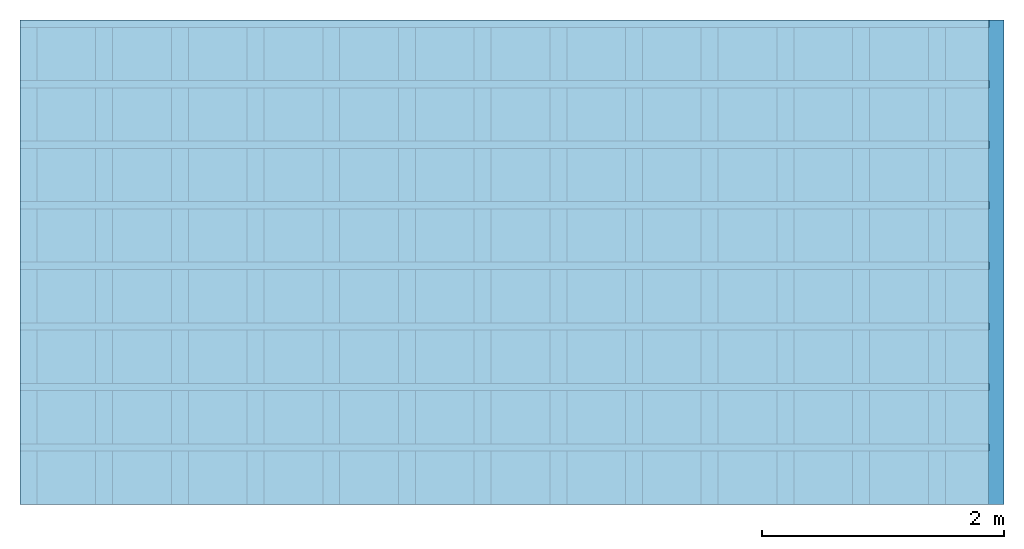
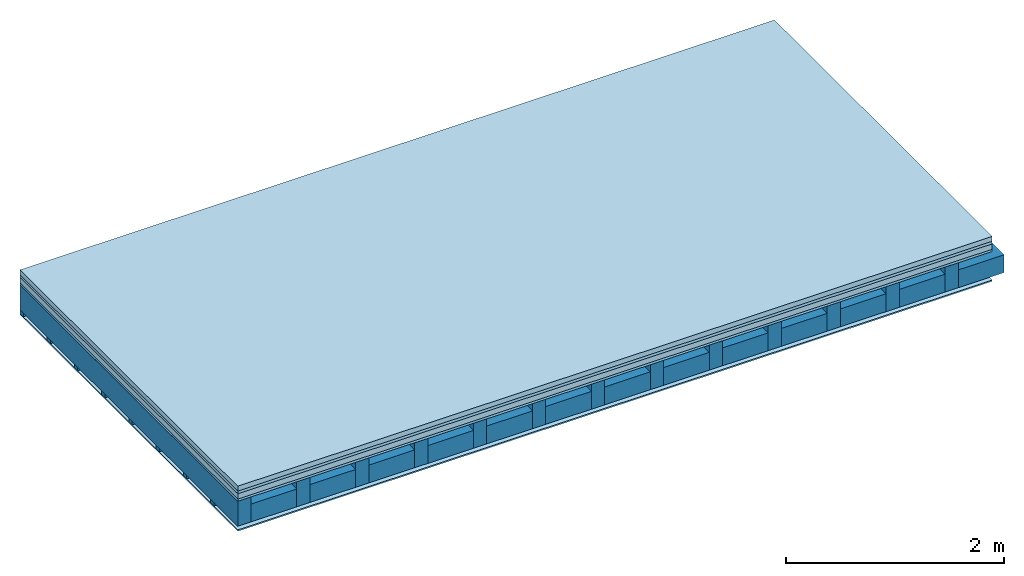
# One storey: 5 plates, 3 members, 1 element without a shape of its own.
"""IFC4 building model written with IfcOpenShell, lengths in metres."""

from ifc_helpers import new_model, si_unit, derived_unit, direction, frame, frame_2d, origin, origin_with_axes, place, context, project, spatial, rectangle, extrude, material, layer, layer_set, type_object, element, aggregate, save


model = new_model("IFC4")

# Units and contexts
plan_context = context("Plan", 3, precision=1e-05, world=origin(), true_north=direction((0.0, 1.0)))
model_context = context("Model", 3, precision=1e-05, world=origin(), true_north=direction((0.0, 1.0)))
ifc_project = project(units=[si_unit("LENGTHUNIT", "METRE"), derived_unit("SOUNDPRESSUREUNIT", [(si_unit("PRESSUREUNIT", "PASCAL", prefix="MICRO"), 0)]), si_unit("ENERGYUNIT", "JOULE", prefix="MEGA"), si_unit("MASSUNIT", "GRAM", prefix="KILO"), derived_unit("THERMALTRANSMITTANCEUNIT", [(si_unit("POWERUNIT", "WATT"), 1), (si_unit("AREAUNIT", "SQUARE_METRE"), -1), (si_unit("THERMODYNAMICTEMPERATUREUNIT", "KELVIN"), -1)]), derived_unit("AREADENSITYUNIT", [(si_unit("MASSUNIT", "GRAM", prefix="KILO"), 1), (si_unit("AREAUNIT", "SQUARE_METRE"), -1)]), derived_unit("USERDEFINED", [(si_unit("ENERGYUNIT", "JOULE", prefix="MEGA"), 1), (si_unit("AREAUNIT", "SQUARE_METRE"), -1)])], contexts=[plan_context, model_context])

# Site, building, storey
site = spatial("IfcSite", under=ifc_project)
building_placement = place(None, origin())
building = spatial("IfcBuilding", under=site, at=building_placement)
storey_placement = place(building_placement, origin())
storey = spatial("IfcBuildingStorey", under=building, at=storey_placement)

# Slab, members, plates
ifc_material_1 = material(Category="04.005")
ifc_layer_1 = layer(ifc_material_1, 0.055, Name="On-material")
ifc_material_2 = material()
ifc_layer_2 = layer(ifc_material_2, 0.03, Name="Impact sound insulation")
ifc_material_3 = material(Name="Cement panels, glued on sub-floor", Category="02.007")
ifc_layer_3 = layer(ifc_material_3, 0.06, Name="on Supporting structure")
ifc_material_4 = material(Category="07.001")
ifc_layer_4 = layer(ifc_material_4, 0.025, Name="Sub-floor")
ifc_material_5 = material(Name="of the art")
ifc_layer_5 = layer(ifc_material_5, 0.0, Name="Bond")
ifc_layer_6 = layer(None, 0.28, Name="Supporting structure")
ifc_layer_7 = layer(ifc_material_5, 0.0, Name="Bond")
ifc_layer_8 = layer(None, 0.04, Name="Battens / profiles")
ifc_material_6 = material(Category="03.007")
ifc_layer_9 = layer(ifc_material_6, 0.015, Name="Ceiling covering 1st layer")
ifc_material_7 = material(Name="Glued joints")
ifc_layer_10 = layer(ifc_material_7, 0.0, Name="Surface / treatment")
ifc_layer_set = layer_set([ifc_layer_1, ifc_layer_2, ifc_layer_3, ifc_layer_4, ifc_layer_5, ifc_layer_6, ifc_layer_7, ifc_layer_8, ifc_layer_9, ifc_layer_10])
slab_type = type_object("IfcSlabType", Name="A0246", PredefinedType="NOTDEFINED", material=ifc_layer_set)
slab_placement = place(None, frame((0.0, 0.0, 0.0), z_axis=(0.0, 0.0, -1.0), x_axis=(1.0, 0.0, 0.0)))
slab = element("IfcSlab", 1, at=slab_placement, inside=storey, type_object=slab_type, material=ifc_layer_set, Name="Slab #1")
ifc_material_8 = material()
member_1_placement = place(slab_placement, origin())
member_1 = element("IfcMember", 2, at=member_1_placement, material=ifc_material_8, Name="Supporting structure", context=plan_context, shape_type="SweptSolid", body=[
    extrude(rectangle(XDim=0.14, YDim=0.28, at=frame_2d((0.07, 0.14), x_axis=(1.0, 0.0))), frame((0.0, 4.0, 0.17), z_axis=(0.0, -1.0, 0.0), x_axis=(1.0, 0.0, 0.0)), (0.0, 0.0, 1.0), 4.0),
    extrude(rectangle(XDim=0.14, YDim=0.28, at=frame_2d((0.07, 0.14), x_axis=(1.0, 0.0))), frame((0.625, 4.0, 0.17), z_axis=(0.0, -1.0, 0.0), x_axis=(1.0, 0.0, 0.0)), (0.0, 0.0, 1.0), 4.0),
    extrude(rectangle(XDim=0.14, YDim=0.28, at=frame_2d((0.07, 0.14), x_axis=(1.0, 0.0))), frame((1.25, 4.0, 0.17), z_axis=(0.0, -1.0, 0.0), x_axis=(1.0, 0.0, 0.0)), (0.0, 0.0, 1.0), 4.0),
    extrude(rectangle(XDim=0.14, YDim=0.28, at=frame_2d((0.07, 0.14), x_axis=(1.0, 0.0))), frame((1.875, 4.0, 0.17), z_axis=(0.0, -1.0, 0.0), x_axis=(1.0, 0.0, 0.0)), (0.0, 0.0, 1.0), 4.0),
    extrude(rectangle(XDim=0.14, YDim=0.28, at=frame_2d((0.07, 0.14), x_axis=(1.0, 0.0))), frame((2.5, 4.0, 0.17), z_axis=(0.0, -1.0, 0.0), x_axis=(1.0, 0.0, 0.0)), (0.0, 0.0, 1.0), 4.0),
    extrude(rectangle(XDim=0.14, YDim=0.28, at=frame_2d((0.07, 0.14), x_axis=(1.0, 0.0))), frame((3.125, 4.0, 0.17), z_axis=(0.0, -1.0, 0.0), x_axis=(1.0, 0.0, 0.0)), (0.0, 0.0, 1.0), 4.0),
    extrude(rectangle(XDim=0.14, YDim=0.28, at=frame_2d((0.07, 0.14), x_axis=(1.0, 0.0))), frame((3.75, 4.0, 0.17), z_axis=(0.0, -1.0, 0.0), x_axis=(1.0, 0.0, 0.0)), (0.0, 0.0, 1.0), 4.0),
    extrude(rectangle(XDim=0.14, YDim=0.28, at=frame_2d((0.07, 0.14), x_axis=(1.0, 0.0))), frame((4.375, 4.0, 0.17), z_axis=(0.0, -1.0, 0.0), x_axis=(1.0, 0.0, 0.0)), (0.0, 0.0, 1.0), 4.0),
    extrude(rectangle(XDim=0.14, YDim=0.28, at=frame_2d((0.07, 0.14), x_axis=(1.0, 0.0))), frame((5.0, 4.0, 0.17), z_axis=(0.0, -1.0, 0.0), x_axis=(1.0, 0.0, 0.0)), (0.0, 0.0, 1.0), 4.0),
    extrude(rectangle(XDim=0.14, YDim=0.28, at=frame_2d((0.07, 0.14), x_axis=(1.0, 0.0))), frame((5.625, 4.0, 0.17), z_axis=(0.0, -1.0, 0.0), x_axis=(1.0, 0.0, 0.0)), (0.0, 0.0, 1.0), 4.0),
    extrude(rectangle(XDim=0.14, YDim=0.28, at=frame_2d((0.07, 0.14), x_axis=(1.0, 0.0))), frame((6.25, 4.0, 0.17), z_axis=(0.0, -1.0, 0.0), x_axis=(1.0, 0.0, 0.0)), (0.0, 0.0, 1.0), 4.0),
    extrude(rectangle(XDim=0.14, YDim=0.28, at=frame_2d((0.07, 0.14), x_axis=(1.0, 0.0))), frame((6.875, 4.0, 0.17), z_axis=(0.0, -1.0, 0.0), x_axis=(1.0, 0.0, 0.0)), (0.0, 0.0, 1.0), 4.0),
    extrude(rectangle(XDim=0.14, YDim=0.28, at=frame_2d((0.07, 0.14), x_axis=(1.0, 0.0))), frame((7.5, 4.0, 0.17), z_axis=(0.0, -1.0, 0.0), x_axis=(1.0, 0.0, 0.0)), (0.0, 0.0, 1.0), 4.0),
])
ifc_material_9 = material()
member_2_placement = place(slab_placement, origin())
member_2 = element("IfcMember", 3, at=member_2_placement, material=ifc_material_9, Name="Cavity", context=plan_context, shape_type="SweptSolid", body=[
    extrude(rectangle(XDim=0.485, YDim=0.2, at=frame_2d((0.2425, 0.1), x_axis=(1.0, 0.0))), frame((0.14, 4.0, 0.25), z_axis=(0.0, -1.0, 0.0), x_axis=(1.0, 0.0, 0.0)), (0.0, 0.0, 1.0), 4.0),
    extrude(rectangle(XDim=0.485, YDim=0.2, at=frame_2d((0.2425, 0.1), x_axis=(1.0, 0.0))), frame((0.765, 4.0, 0.25), z_axis=(0.0, -1.0, 0.0), x_axis=(1.0, 0.0, 0.0)), (0.0, 0.0, 1.0), 4.0),
    extrude(rectangle(XDim=0.485, YDim=0.2, at=frame_2d((0.2425, 0.1), x_axis=(1.0, 0.0))), frame((1.39, 4.0, 0.25), z_axis=(0.0, -1.0, 0.0), x_axis=(1.0, 0.0, 0.0)), (0.0, 0.0, 1.0), 4.0),
    extrude(rectangle(XDim=0.485, YDim=0.2, at=frame_2d((0.2425, 0.1), x_axis=(1.0, 0.0))), frame((2.015, 4.0, 0.25), z_axis=(0.0, -1.0, 0.0), x_axis=(1.0, 0.0, 0.0)), (0.0, 0.0, 1.0), 4.0),
    extrude(rectangle(XDim=0.485, YDim=0.2, at=frame_2d((0.2425, 0.1), x_axis=(1.0, 0.0))), frame((2.64, 4.0, 0.25), z_axis=(0.0, -1.0, 0.0), x_axis=(1.0, 0.0, 0.0)), (0.0, 0.0, 1.0), 4.0),
    extrude(rectangle(XDim=0.485, YDim=0.2, at=frame_2d((0.2425, 0.1), x_axis=(1.0, 0.0))), frame((3.265, 4.0, 0.25), z_axis=(0.0, -1.0, 0.0), x_axis=(1.0, 0.0, 0.0)), (0.0, 0.0, 1.0), 4.0),
    extrude(rectangle(XDim=0.485, YDim=0.2, at=frame_2d((0.2425, 0.1), x_axis=(1.0, 0.0))), frame((3.89, 4.0, 0.25), z_axis=(0.0, -1.0, 0.0), x_axis=(1.0, 0.0, 0.0)), (0.0, 0.0, 1.0), 4.0),
    extrude(rectangle(XDim=0.485, YDim=0.2, at=frame_2d((0.2425, 0.1), x_axis=(1.0, 0.0))), frame((4.515, 4.0, 0.25), z_axis=(0.0, -1.0, 0.0), x_axis=(1.0, 0.0, 0.0)), (0.0, 0.0, 1.0), 4.0),
    extrude(rectangle(XDim=0.485, YDim=0.2, at=frame_2d((0.2425, 0.1), x_axis=(1.0, 0.0))), frame((5.14, 4.0, 0.25), z_axis=(0.0, -1.0, 0.0), x_axis=(1.0, 0.0, 0.0)), (0.0, 0.0, 1.0), 4.0),
    extrude(rectangle(XDim=0.485, YDim=0.2, at=frame_2d((0.2425, 0.1), x_axis=(1.0, 0.0))), frame((5.765, 4.0, 0.25), z_axis=(0.0, -1.0, 0.0), x_axis=(1.0, 0.0, 0.0)), (0.0, 0.0, 1.0), 4.0),
    extrude(rectangle(XDim=0.485, YDim=0.2, at=frame_2d((0.2425, 0.1), x_axis=(1.0, 0.0))), frame((6.39, 4.0, 0.25), z_axis=(0.0, -1.0, 0.0), x_axis=(1.0, 0.0, 0.0)), (0.0, 0.0, 1.0), 4.0),
    extrude(rectangle(XDim=0.485, YDim=0.2, at=frame_2d((0.2425, 0.1), x_axis=(1.0, 0.0))), frame((7.015, 4.0, 0.25), z_axis=(0.0, -1.0, 0.0), x_axis=(1.0, 0.0, 0.0)), (0.0, 0.0, 1.0), 4.0),
    extrude(rectangle(XDim=0.485, YDim=0.2, at=frame_2d((0.2425, 0.1), x_axis=(1.0, 0.0))), frame((7.64, 4.0, 0.25), z_axis=(0.0, -1.0, 0.0), x_axis=(1.0, 0.0, 0.0)), (0.0, 0.0, 1.0), 4.0),
])
ifc_material_10 = material()
member_3_placement = place(slab_placement, origin())
member_3 = element("IfcMember", 4, at=member_3_placement, material=ifc_material_10, Name="Battens / profiles", context=plan_context, shape_type="SweptSolid", body=[
    extrude(rectangle(XDim=0.06, YDim=0.04, at=frame_2d((0.03, 0.02), x_axis=(1.0, 0.0))), frame((0.0, 0.0, 0.45), z_axis=(1.0, 0.0, 0.0), x_axis=(0.0, 1.0, 0.0)), (0.0, 0.0, 1.0), 8.0),
    extrude(rectangle(XDim=0.06, YDim=0.04, at=frame_2d((0.03, 0.02), x_axis=(1.0, 0.0))), frame((0.0, 0.5, 0.45), z_axis=(1.0, 0.0, 0.0), x_axis=(0.0, 1.0, 0.0)), (0.0, 0.0, 1.0), 8.0),
    extrude(rectangle(XDim=0.06, YDim=0.04, at=frame_2d((0.03, 0.02), x_axis=(1.0, 0.0))), frame((0.0, 1.0, 0.45), z_axis=(1.0, 0.0, 0.0), x_axis=(0.0, 1.0, 0.0)), (0.0, 0.0, 1.0), 8.0),
    extrude(rectangle(XDim=0.06, YDim=0.04, at=frame_2d((0.03, 0.02), x_axis=(1.0, 0.0))), frame((0.0, 1.5, 0.45), z_axis=(1.0, 0.0, 0.0), x_axis=(0.0, 1.0, 0.0)), (0.0, 0.0, 1.0), 8.0),
    extrude(rectangle(XDim=0.06, YDim=0.04, at=frame_2d((0.03, 0.02), x_axis=(1.0, 0.0))), frame((0.0, 2.0, 0.45), z_axis=(1.0, 0.0, 0.0), x_axis=(0.0, 1.0, 0.0)), (0.0, 0.0, 1.0), 8.0),
    extrude(rectangle(XDim=0.06, YDim=0.04, at=frame_2d((0.03, 0.02), x_axis=(1.0, 0.0))), frame((0.0, 2.5, 0.45), z_axis=(1.0, 0.0, 0.0), x_axis=(0.0, 1.0, 0.0)), (0.0, 0.0, 1.0), 8.0),
    extrude(rectangle(XDim=0.06, YDim=0.04, at=frame_2d((0.03, 0.02), x_axis=(1.0, 0.0))), frame((0.0, 3.0, 0.45), z_axis=(1.0, 0.0, 0.0), x_axis=(0.0, 1.0, 0.0)), (0.0, 0.0, 1.0), 8.0),
    extrude(rectangle(XDim=0.06, YDim=0.04, at=frame_2d((0.03, 0.02), x_axis=(1.0, 0.0))), frame((0.0, 3.5, 0.45), z_axis=(1.0, 0.0, 0.0), x_axis=(0.0, 1.0, 0.0)), (0.0, 0.0, 1.0), 8.0),
])
plate_1_placement = place(slab_placement, origin())
plate_1 = element("IfcPlate", 5, at=plate_1_placement, material=ifc_material_1, Name="On-material", context=plan_context, shape_type="SweptSolid", body=[
    extrude(rectangle(XDim=8.0, YDim=4.0, at=frame_2d((4.0, 2.0), x_axis=(1.0, 0.0))), origin_with_axes(), (0.0, 0.0, 1.0), 0.055),
])
plate_2_placement = place(slab_placement, origin())
plate_2 = element("IfcPlate", 6, at=plate_2_placement, material=ifc_material_2, Name="Impact sound insulation", context=plan_context, shape_type="SweptSolid", body=[
    extrude(rectangle(XDim=8.0, YDim=4.0, at=frame_2d((4.0, 2.0), x_axis=(1.0, 0.0))), frame((0.0, 0.0, 0.055), z_axis=(0.0, 0.0, 1.0), x_axis=(1.0, 0.0, 0.0)), (0.0, 0.0, 1.0), 0.03),
])
plate_3_placement = place(slab_placement, origin())
plate_3 = element("IfcPlate", 7, at=plate_3_placement, material=ifc_material_3, Name="on Supporting structure", context=plan_context, shape_type="SweptSolid", body=[
    extrude(rectangle(XDim=8.0, YDim=4.0, at=frame_2d((4.0, 2.0), x_axis=(1.0, 0.0))), frame((0.0, 0.0, 0.085), z_axis=(0.0, 0.0, 1.0), x_axis=(1.0, 0.0, 0.0)), (0.0, 0.0, 1.0), 0.06),
])
plate_4_placement = place(slab_placement, origin())
plate_4 = element("IfcPlate", 8, at=plate_4_placement, material=ifc_material_4, Name="Sub-floor", context=plan_context, shape_type="SweptSolid", body=[
    extrude(rectangle(XDim=8.0, YDim=4.0, at=frame_2d((4.0, 2.0), x_axis=(1.0, 0.0))), frame((0.0, 0.0, 0.145), z_axis=(0.0, 0.0, 1.0), x_axis=(1.0, 0.0, 0.0)), (0.0, 0.0, 1.0), 0.025),
])
plate_5_placement = place(slab_placement, origin())
plate_5 = element("IfcPlate", 9, at=plate_5_placement, material=ifc_material_6, Name="Ceiling covering 1st layer", context=plan_context, shape_type="SweptSolid", body=[
    extrude(rectangle(XDim=8.0, YDim=4.0, at=frame_2d((4.0, 2.0), x_axis=(1.0, 0.0))), frame((0.0, 0.0, 0.49), z_axis=(0.0, 0.0, 1.0), x_axis=(1.0, 0.0, 0.0)), (0.0, 0.0, 1.0), 0.015),
])
aggregate(slab, [plate_1, plate_2, plate_3, plate_4, member_1, member_2, member_3, plate_5])

save(model, "model.ifc")
